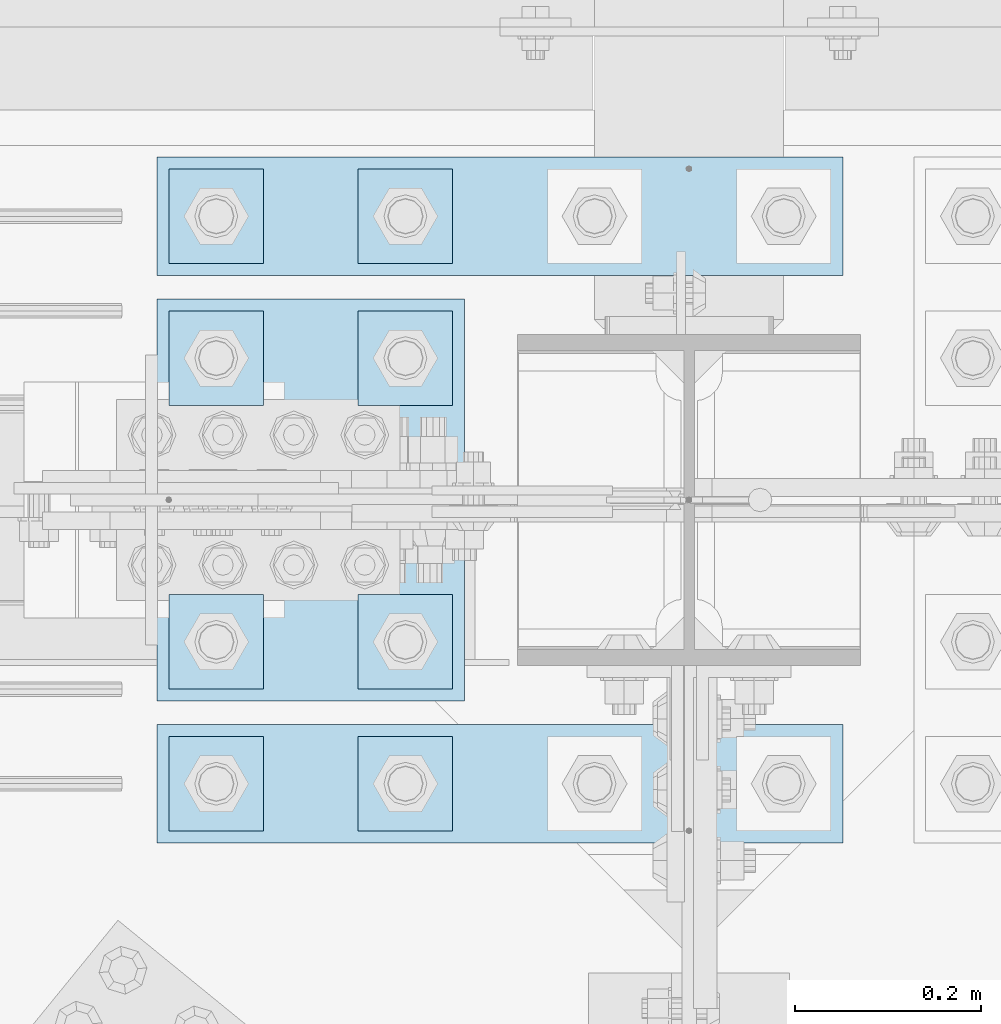
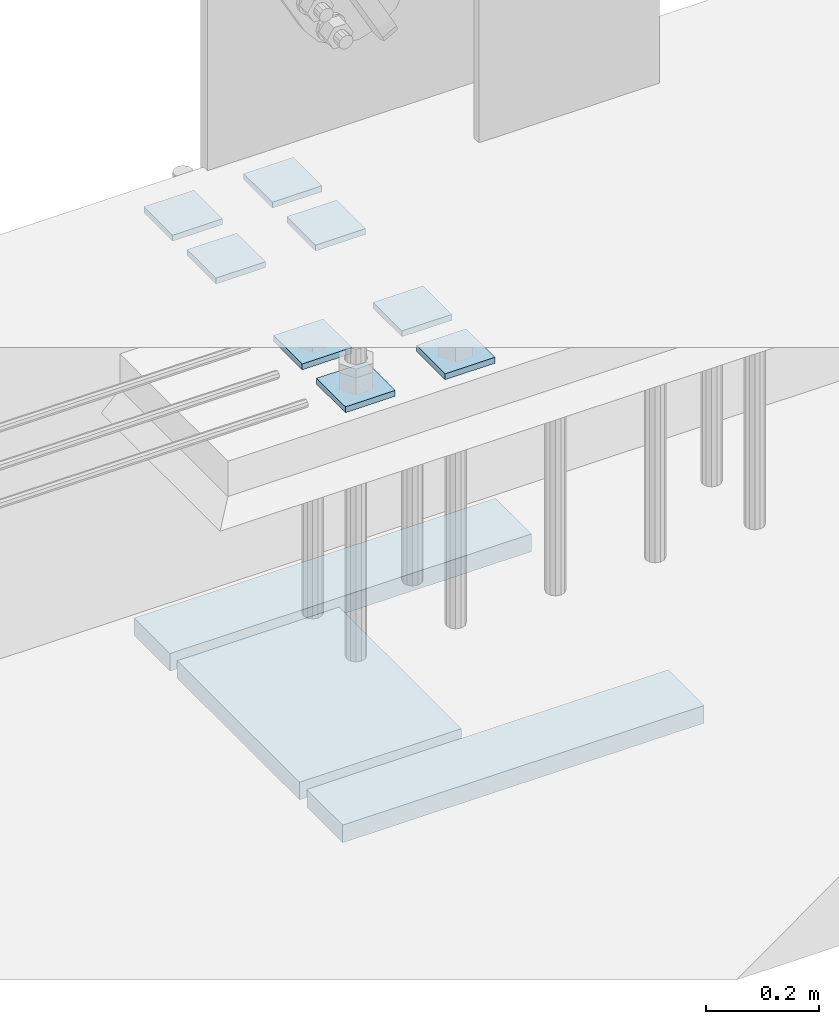
# One storey, part 3492 of 3843: 11 plates, 1 element without a shape of its own.
"""IFC2X3 building model written with IfcOpenShell, lengths in millimetres."""

import ifcopenshell
import ifcopenshell.guid

model = None  # the IFC model being written
_history = None  # IfcOwnerHistory: only IFC2X3 demands one
_inside = {}  # id of a spatial element -> (the spatial element, [elements in it])
_under = {}  # id of a project, library or spatial element -> (it, [spatial elements below it])
_declared = {}  # id of a project -> (the project, [libraries it declares])
_typed = {}  # id of a type object -> (the type object, [elements of that type])
_made_of = {}  # id of a material, layer set ... -> (it, [elements and type objects made of it])


def new_model(schema):
    """Start an empty IFC model of exactly this schema.

    Asked for "IFC4X3", IfcOpenShell would pick the latest addendum, in which some entities
    have other attributes; the version numbers below select the first issue.
    IFC2X3 requires an IfcOwnerHistory on every rooted entity: one is made here for all.
    """
    global model, _history
    if schema == "IFC4X3":
        model = ifcopenshell.file(schema_version=(4, 3, 0, 0))
    else:
        model = ifcopenshell.file(schema=schema)
    _inside.clear()
    _under.clear()
    _declared.clear()
    _typed.clear()
    _made_of.clear()
    _history = None
    if model.schema == "IFC2X3":
        org = make("IfcOrganization", Name="unknown")
        user = make(
            "IfcPersonAndOrganization",
            ThePerson=make("IfcPerson", FamilyName="unknown"),
            TheOrganization=org,
        )
        app = make(
            "IfcApplication",
            ApplicationDeveloper=org,
            Version="unknown",
            ApplicationFullName="unknown",
            ApplicationIdentifier="unknown",
        )
        _history = make(
            "IfcOwnerHistory",
            OwningUser=user,
            OwningApplication=app,
            ChangeAction="ADDED",
            CreationDate=0,
        )
    return model


def make(cls, **values):
    """One entity of the class cls with the attributes given. An attribute that is None is left unset."""
    return model.create_entity(
        cls, **{name: value for name, value in values.items() if value is not None}
    )


def rooted(cls, **values):
    """An entity with a GlobalId (a new one), such as an element, a storey or a relation."""
    return make(cls, GlobalId=ifcopenshell.guid.new(), OwnerHistory=_history, **values)


def si_unit(unit_type, name, prefix=None):
    """IfcSIUnit, for example si_unit("LENGTHUNIT", "METRE", prefix="MILLI")."""
    return make("IfcSIUnit", UnitType=unit_type, Prefix=prefix, Name=name)


def assignment(units):
    """IfcUnitAssignment: the units of a project."""
    return None if units is None else make("IfcUnitAssignment", Units=units)


def point(xyz):
    """IfcCartesianPoint."""
    return None if xyz is None else make("IfcCartesianPoint", Coordinates=xyz)


def direction(xyz):
    """IfcDirection."""
    return None if xyz is None else make("IfcDirection", DirectionRatios=xyz)


def frame(location, z_axis=None, x_axis=None):
    """IfcAxis2Placement3D, a coordinate frame: its origin and axes. An axis left out is left unset."""
    return make(
        "IfcAxis2Placement3D",
        Location=point(location),
        Axis=direction(z_axis),
        RefDirection=direction(x_axis),
    )


def origin_with_axes():
    """The frame at (0, 0, 0) with the z axis (0, 0, 1) and the x axis (1, 0, 0) written out."""
    return frame((0.0, 0.0, 0.0), z_axis=(0.0, 0.0, 1.0), x_axis=(1.0, 0.0, 0.0))


def place(relative_to, where):
    """IfcLocalPlacement: puts the frame where relative to a parent placement (None: the world)."""
    return make(
        "IfcLocalPlacement", PlacementRelTo=relative_to, RelativePlacement=where
    )


def context(
    kind, dimensions, precision=None, world=None, true_north=None, identifier=None
):
    """IfcGeometricRepresentationContext, for example the 3D "Model" context."""
    return make(
        "IfcGeometricRepresentationContext",
        ContextIdentifier=identifier,
        ContextType=kind,
        CoordinateSpaceDimension=dimensions,
        Precision=precision,
        WorldCoordinateSystem=world,
        TrueNorth=true_north,
    )


def subcontext(parent, identifier, kind, view, scale=None):
    """IfcGeometricRepresentationSubContext, for example "Body" below "Model"."""
    return make(
        "IfcGeometricRepresentationSubContext",
        ContextIdentifier=identifier,
        ContextType=kind,
        ParentContext=parent,
        TargetScale=scale,
        TargetView=view,
    )


def project(units=None, contexts=None):
    """IfcProject with its units and contexts."""
    return rooted(
        "IfcProject",
        Name="project",
        RepresentationContexts=contexts,
        UnitsInContext=assignment(units),
    )


def spatial(cls, under=None, at=None, **own):
    """A site, building, storey or space (cls), placed at a placement, below another one or the project."""
    s = rooted(cls, ObjectPlacement=at, **own)
    if under is not None:
        _under.setdefault(under.id(), (under, []))[1].append(s)
    return s


def faces_of(points, faces, orient=None, outer=None):
    """IfcFace entities. A face is a list of loops; a loop is a list of indices into points, from 0.

    orient and outer hold one flag for each loop. By default every Orientation is true, the
    first loop of a face is its IfcFaceOuterBound and the others are IfcFaceBound.
    """
    made = []
    for i, loops in enumerate(faces):
        bounds = []
        for j, loop in enumerate(loops):
            is_outer = j == 0 if outer is None else outer[i][j]
            bounds.append(
                make(
                    "IfcFaceOuterBound" if is_outer else "IfcFaceBound",
                    Bound=make("IfcPolyLoop", Polygon=[points[k] for k in loop]),
                    Orientation=True if orient is None else orient[i][j],
                )
            )
        made.append(make("IfcFace", Bounds=bounds))
    return made


def faceted_brep(points, faces, orient=None, outer=None, voids=None):
    """IfcFacetedBrep: a solid bounded by flat faces; with voids (closed shells), ...WithVoids."""
    shared = [point(p) for p in points]
    hull = make("IfcClosedShell", CfsFaces=faces_of(shared, faces, orient, outer))
    if voids is None:
        return make("IfcFacetedBrep", Outer=hull)
    return make(
        "IfcFacetedBrepWithVoids",
        Outer=hull,
        Voids=[
            make(cls, CfsFaces=faces_of(shared, fs, o, b)) for cls, fs, o, b in voids
        ],
    )


def shape(context_of_items, identifier, shape_type, items):
    """IfcShapeRepresentation: the items that make up one representation, for example the "Body"."""
    return make(
        "IfcShapeRepresentation",
        ContextOfItems=context_of_items,
        RepresentationIdentifier=identifier,
        RepresentationType=shape_type,
        Items=items,
    )


def material(Name=None, Category=None):
    """IfcMaterial."""
    return make("IfcMaterial", Name=Name, Category=Category)


def made_of(thing, what):
    """Note that an element or type object is made of a material, layer set ...; save() writes the relation."""
    if what is not None:
        _made_of.setdefault(what.id(), (what, []))[1].append(thing)
    return thing


def type_object(cls, material=None, **own):
    """A type object (cls), such as IfcWallType, which elements share."""
    return made_of(rooted(cls, **own), material)


def element(
    cls,
    number,
    at=None,
    inside=None,
    cuts=None,
    type_object=None,
    material=None,
    context=None,
    identifier="Body",
    shape_type=None,
    held_by="IfcProductDefinitionShape",
    body=None,
    shapes=None,
    **own,
):
    """One element of the class cls, such as IfcWall. Its Tag is "e" and its number.

    at: its placement. inside: the storey or other place that contains it. cuts: it is an
    opening in that element (IfcRelVoidsElement). A single representation is given by context,
    identifier, shape_type and body (its items); several are given by shapes. held_by: the class
    of the entity that holds the representations. save() writes the other relations.
    """
    e = rooted(cls, Tag="e%d" % number, ObjectPlacement=at, **own)
    if body is not None:
        shapes = [shape(context, identifier, shape_type, body)]
    if shapes is not None:
        e.Representation = make(held_by, Representations=shapes)
    if inside is not None:
        _inside.setdefault(inside.id(), (inside, []))[1].append(e)
    if cuts is not None:
        rooted(
            "IfcRelVoidsElement", RelatingBuildingElement=cuts, RelatedOpeningElement=e
        )
    if type_object is not None:
        _typed.setdefault(type_object.id(), (type_object, []))[1].append(e)
    return made_of(e, material)


def aggregate(whole, parts):
    """IfcRelAggregates: a whole, such as a stair, and the parts it consists of."""
    return rooted("IfcRelAggregates", RelatingObject=whole, RelatedObjects=parts)


def save(model, path):
    """Write the relations noted so far, then the file.

    IfcRelAggregates (storeys below a building ...), IfcRelContainedInSpatialStructure (elements
    in a storey), IfcRelDefinesByType, IfcRelAssociatesMaterial and IfcRelDeclares: one each for
    every whole, place, type object, material and project.
    """
    for whole, parts in _under.values():
        aggregate(whole, parts)
    for where, things in _inside.values():
        rooted(
            "IfcRelContainedInSpatialStructure",
            RelatedElements=things,
            RelatingStructure=where,
        )
    for kind, things in _typed.values():
        rooted("IfcRelDefinesByType", RelatedObjects=things, RelatingType=kind)
    for what, things in _made_of.values():
        rooted("IfcRelAssociatesMaterial", RelatedObjects=things, RelatingMaterial=what)
    for by, libraries in _declared.values():
        rooted("IfcRelDeclares", RelatingContext=by, RelatedDefinitions=libraries)
    model.write(path)


model = new_model("IFC2X3")

# Units and contexts
model_context = context("Model", 3, precision=1e-05, world=origin_with_axes())
body_context = subcontext(model_context, "Body", "Model", "MODEL_VIEW")
ifc_project = project(units=[si_unit("LENGTHUNIT", "METRE", prefix="MILLI"), si_unit("AREAUNIT", "SQUARE_METRE"), si_unit("VOLUMEUNIT", "CUBIC_METRE"), si_unit("MASSUNIT", "GRAM", prefix="KILO"), si_unit("TIMEUNIT", "SECOND"), si_unit("PLANEANGLEUNIT", "RADIAN"), si_unit("SOLIDANGLEUNIT", "STERADIAN"), si_unit("THERMODYNAMICTEMPERATUREUNIT", "DEGREE_CELSIUS"), si_unit("LUMINOUSINTENSITYUNIT", "LUMEN")], contexts=[model_context])

# Site, building, storey
site_placement = place(None, origin_with_axes())
site = spatial("IfcSite", under=ifc_project, at=site_placement, CompositionType="ELEMENT")
building_placement = place(site_placement, origin_with_axes())
building = spatial("IfcBuilding", under=site, at=building_placement, Name="Undefined", CompositionType="ELEMENT")
storey_placement = place(building_placement, origin_with_axes())
storey = spatial("IfcBuildingStorey", under=building, at=storey_placement, Name="Undefined", CompositionType="ELEMENT", Elevation=0.0)

# Assembly, plates
assembly_placement = place(storey_placement, origin_with_axes())
assembly = element("IfcElementAssembly", 1, at=assembly_placement, inside=storey, Name="TEMPLATE", AssemblyPlace="NOTDEFINED", PredefinedType="RIGID_FRAME")
ifc_material = material(Name="STEEL/A572-50")
plate_type_1 = type_object("IfcPlateType", PredefinedType="NOTDEFINED")
plate_1_placement = place(assembly_placement, frame((62179.2, 91960.7, 30143.45), z_axis=(-1.0, 0.0, 0.0), x_axis=(0.0, -1.0, 0.0)))
plate_1 = element("IfcPlate", 2, at=plate_1_placement, type_object=plate_type_1, material=ifc_material, Name="Washer Plate", context=body_context, shape_type="Brep", body=[
    faceted_brep([(0.0, -6.3499999046162, 0.0), (-1.67347025126219e-10, -6.35000000000582, 101.600000000151), (-1.67347025126219e-10, 6.35000000000582, 101.600000000151), (7.27595761418343e-12, 6.3499999046162, 0.0), (101.599998474121, -6.34999999999854, 101.599998474121), (101.599998474121, 6.34999999999854, 101.599998474121), (101.6, -6.34999999999854, 0.0), (101.6, 6.34999999999854, 0.0)], [[[0, 1, 2, 3]], [[1, 4, 5, 2]], [[4, 6, 7, 5]], [[6, 0, 3, 7]], [[5, 7, 3, 2]], [[6, 4, 1, 0]]]),
])
plate_2_placement = place(assembly_placement, frame((62382.4, 91960.7, 30143.45), z_axis=(-1.0, 0.0, 0.0), x_axis=(0.0, -1.0, 0.0)))
plate_2 = element("IfcPlate", 3, at=plate_2_placement, type_object=plate_type_1, material=ifc_material, Name="Washer Plate", context=body_context, shape_type="Brep", body=[
    faceted_brep([(0.0, -6.3499999046162, 0.0), (-1.67347025126219e-10, -6.35000000000582, 101.600000000151), (-1.67347025126219e-10, 6.35000000000582, 101.600000000151), (7.27595761418343e-12, 6.3499999046162, 0.0), (101.599998474121, -6.34999999999854, 101.599998474121), (101.599998474121, 6.34999999999854, 101.599998474121), (101.6, -6.34999999999854, 0.0), (101.6, 6.34999999999854, 0.0)], [[[0, 1, 2, 3]], [[1, 4, 5, 2]], [[4, 6, 7, 5]], [[6, 0, 3, 7]], [[5, 7, 3, 2]], [[6, 4, 1, 0]]]),
])
plate_3_placement = place(assembly_placement, frame((62179.2, 92113.1, 30143.45), z_axis=(-1.0, 0.0, 0.0), x_axis=(0.0, -1.0, 0.0)))
plate_3 = element("IfcPlate", 4, at=plate_3_placement, type_object=plate_type_1, material=ifc_material, Name="Washer Plate", context=body_context, shape_type="Brep", body=[
    faceted_brep([(0.0, -6.3499999046162, 0.0), (-1.67347025126219e-10, -6.35000000000582, 101.600000000151), (-1.67347025126219e-10, 6.35000000000582, 101.600000000151), (7.27595761418343e-12, 6.3499999046162, 0.0), (101.599998474121, -6.34999999999854, 101.599998474121), (101.599998474121, 6.34999999999854, 101.599998474121), (101.6, -6.34999999999854, 0.0), (101.6, 6.34999999999854, 0.0)], [[[0, 1, 2, 3]], [[1, 4, 5, 2]], [[4, 6, 7, 5]], [[6, 0, 3, 7]], [[5, 7, 3, 2]], [[6, 4, 1, 0]]]),
])
plate_4_placement = place(assembly_placement, frame((62382.4, 92113.1, 30143.45), z_axis=(-1.0, 0.0, 0.0), x_axis=(0.0, -1.0, 0.0)))
plate_4 = element("IfcPlate", 5, at=plate_4_placement, type_object=plate_type_1, material=ifc_material, Name="Washer Plate", context=body_context, shape_type="Brep", body=[
    faceted_brep([(0.0, -6.3499999046162, 0.0), (-1.67347025126219e-10, -6.35000000000582, 101.600000000151), (-1.67347025126219e-10, 6.35000000000582, 101.600000000151), (7.27595761418343e-12, 6.3499999046162, 0.0), (101.599998474121, -6.34999999999854, 101.599998474121), (101.599998474121, 6.34999999999854, 101.599998474121), (101.6, -6.34999999999854, 0.0), (101.6, 6.34999999999854, 0.0)], [[[0, 1, 2, 3]], [[1, 4, 5, 2]], [[4, 6, 7, 5]], [[6, 0, 3, 7]], [[5, 7, 3, 2]], [[6, 4, 1, 0]]]),
])
plate_5_placement = place(assembly_placement, frame((62179.2, 92417.9, 30143.45), z_axis=(-1.0, 0.0, 0.0), x_axis=(0.0, -1.0, 0.0)))
plate_5 = element("IfcPlate", 6, at=plate_5_placement, type_object=plate_type_1, material=ifc_material, Name="Washer Plate", context=body_context, shape_type="Brep", body=[
    faceted_brep([(0.0, -6.3499999046162, 0.0), (-1.67347025126219e-10, -6.35000000000582, 101.600000000151), (-1.67347025126219e-10, 6.35000000000582, 101.600000000151), (7.27595761418343e-12, 6.3499999046162, 0.0), (101.599998474121, -6.34999999999854, 101.599998474121), (101.599998474121, 6.34999999999854, 101.599998474121), (101.6, -6.34999999999854, 0.0), (101.6, 6.34999999999854, 0.0)], [[[0, 1, 2, 3]], [[1, 4, 5, 2]], [[4, 6, 7, 5]], [[6, 0, 3, 7]], [[5, 7, 3, 2]], [[6, 4, 1, 0]]]),
])
plate_6_placement = place(assembly_placement, frame((62382.4, 92417.9, 30143.45), z_axis=(-1.0, 0.0, 0.0), x_axis=(0.0, -1.0, 0.0)))
plate_6 = element("IfcPlate", 7, at=plate_6_placement, type_object=plate_type_1, material=ifc_material, Name="Washer Plate", context=body_context, shape_type="Brep", body=[
    faceted_brep([(0.0, -6.3499999046162, 0.0), (-1.67347025126219e-10, -6.35000000000582, 101.600000000151), (-1.67347025126219e-10, 6.35000000000582, 101.600000000151), (7.27595761418343e-12, 6.3499999046162, 0.0), (101.599998474121, -6.34999999999854, 101.599998474121), (101.599998474121, 6.34999999999854, 101.599998474121), (101.6, -6.34999999999854, 0.0), (101.6, 6.34999999999854, 0.0)], [[[0, 1, 2, 3]], [[1, 4, 5, 2]], [[4, 6, 7, 5]], [[6, 0, 3, 7]], [[5, 7, 3, 2]], [[6, 4, 1, 0]]]),
])
plate_7_placement = place(assembly_placement, frame((62179.2, 92570.3, 30143.45), z_axis=(-1.0, 0.0, 0.0), x_axis=(0.0, -1.0, 0.0)))
plate_7 = element("IfcPlate", 8, at=plate_7_placement, type_object=plate_type_1, material=ifc_material, Name="Washer Plate", context=body_context, shape_type="Brep", body=[
    faceted_brep([(0.0, -6.3499999046162, 0.0), (-1.67347025126219e-10, -6.35000000000582, 101.600000000151), (-1.67347025126219e-10, 6.35000000000582, 101.600000000151), (7.27595761418343e-12, 6.3499999046162, 0.0), (101.599998474121, -6.34999999999854, 101.599998474121), (101.599998474121, 6.34999999999854, 101.599998474121), (101.6, -6.34999999999854, 0.0), (101.6, 6.34999999999854, 0.0)], [[[0, 1, 2, 3]], [[1, 4, 5, 2]], [[4, 6, 7, 5]], [[6, 0, 3, 7]], [[5, 7, 3, 2]], [[6, 4, 1, 0]]]),
])
plate_8_placement = place(assembly_placement, frame((62382.4, 92570.3, 30143.45), z_axis=(-1.0, 0.0, 0.0), x_axis=(0.0, -1.0, 0.0)))
plate_8 = element("IfcPlate", 9, at=plate_8_placement, type_object=plate_type_1, material=ifc_material, Name="Washer Plate", context=body_context, shape_type="Brep", body=[
    faceted_brep([(0.0, -6.3499999046162, 0.0), (-1.67347025126219e-10, -6.35000000000582, 101.600000000151), (-1.67347025126219e-10, 6.35000000000582, 101.600000000151), (7.27595761418343e-12, 6.3499999046162, 0.0), (101.599998474121, -6.34999999999854, 101.599998474121), (101.599998474121, 6.34999999999854, 101.599998474121), (101.6, -6.34999999999854, 0.0), (101.6, 6.34999999999854, 0.0)], [[[0, 1, 2, 3]], [[1, 4, 5, 2]], [[4, 6, 7, 5]], [[6, 0, 3, 7]], [[5, 7, 3, 2]], [[6, 4, 1, 0]]]),
])
plate_type_2 = type_object("IfcPlateType", PredefinedType="NOTDEFINED")
plate_9_placement = place(assembly_placement, frame((62064.9, 92583.0, 29241.75), z_axis=(1.0, 0.0, 0.0), x_axis=(0.0, -1.0, 0.0)))
plate_9 = element("IfcPlate", 10, at=plate_9_placement, type_object=plate_type_2, material=ifc_material, Name="PLATE", context=body_context, shape_type="Brep", body=[
    faceted_brep([(0.0, -19.0500000000029, 0.0), (0.0, -19.0499999999993, 736.600036621094), (0.0, 19.0499999999993, 736.600036621094), (0.0, 19.0500000000029, 0.0), (127.0, -19.0499999999993, 736.600036621094), (127.0, 19.0499999999993, 736.600036621094), (127.0, -19.0499999999993, 0.0), (127.0, 19.0499999999993, 0.0)], [[[0, 1, 2, 3]], [[1, 4, 5, 2]], [[4, 6, 7, 5]], [[6, 0, 3, 7]], [[5, 7, 3, 2]], [[6, 4, 1, 0]]]),
])
plate_10_placement = place(assembly_placement, frame((62064.9, 91973.4, 29241.75), z_axis=(1.0, 0.0, 0.0), x_axis=(0.0, -1.0, 0.0)))
plate_10 = element("IfcPlate", 11, at=plate_10_placement, type_object=plate_type_2, material=ifc_material, Name="PLATE", context=body_context, shape_type="Brep", body=[
    faceted_brep([(0.0, -19.0500000000029, 0.0), (0.0, -19.0499999999993, 736.600036621094), (0.0, 19.0499999999993, 736.600036621094), (0.0, 19.0500000000029, 0.0), (127.0, -19.0499999999993, 736.600036621094), (127.0, 19.0499999999993, 736.600036621094), (127.0, -19.0499999999993, 0.0), (127.0, 19.0499999999993, 0.0)], [[[0, 1, 2, 3]], [[1, 4, 5, 2]], [[4, 6, 7, 5]], [[6, 0, 3, 7]], [[5, 7, 3, 2]], [[6, 4, 1, 0]]]),
])
plate_type_3 = type_object("IfcPlateType", PredefinedType="NOTDEFINED")
plate_11_placement = place(assembly_placement, frame((62064.9, 92430.6, 29241.75), z_axis=(1.0, 0.0, 0.0), x_axis=(0.0, -1.0, 0.0)))
plate_11 = element("IfcPlate", 12, at=plate_11_placement, type_object=plate_type_3, material=ifc_material, Name="PLATE", context=body_context, shape_type="Brep", body=[
    faceted_brep([(0.0, -19.0500000000029, 0.0), (0.0, -19.0499999999993, 330.200012207031), (0.0, 19.0499999999993, 330.200012207031), (0.0, 19.0500000000029, 0.0), (431.799957275391, -19.0499999999993, 330.200012207031), (431.799957275391, 19.0499999999993, 330.200012207031), (431.799957275391, -19.0499999999993, 0.0), (431.799957275391, 19.0499999999993, 0.0)], [[[0, 1, 2, 3]], [[1, 4, 5, 2]], [[4, 6, 7, 5]], [[6, 0, 3, 7]], [[5, 7, 3, 2]], [[6, 4, 1, 0]]]),
])
aggregate(assembly, [plate_9, plate_10, plate_11, plate_1, plate_2, plate_3, plate_4, plate_5, plate_6, plate_7, plate_8])

save(model, "model.ifc")
